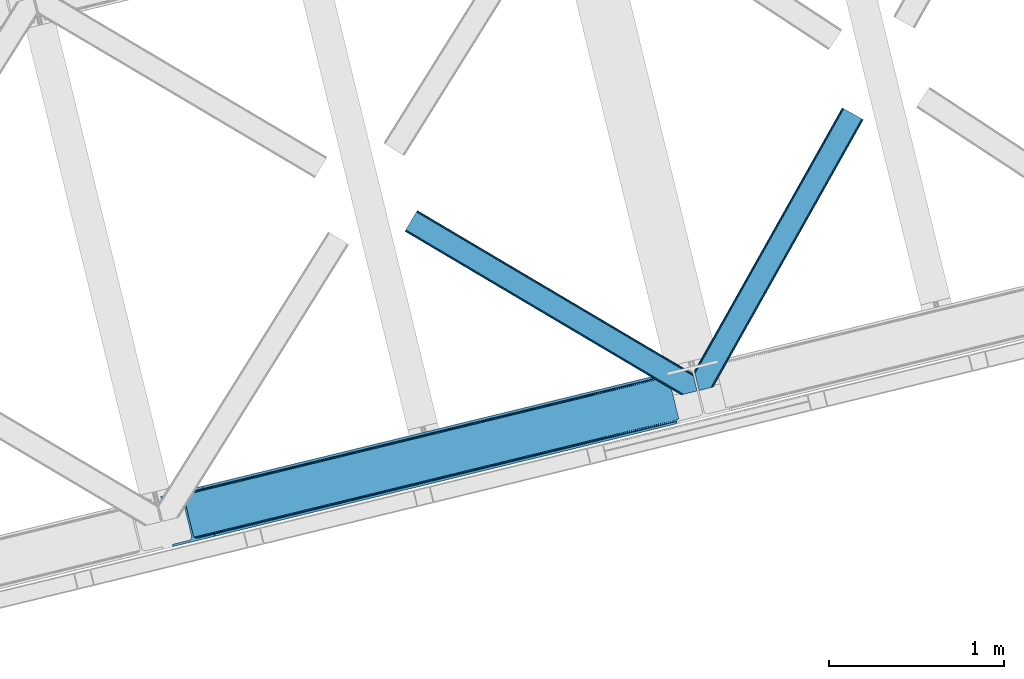
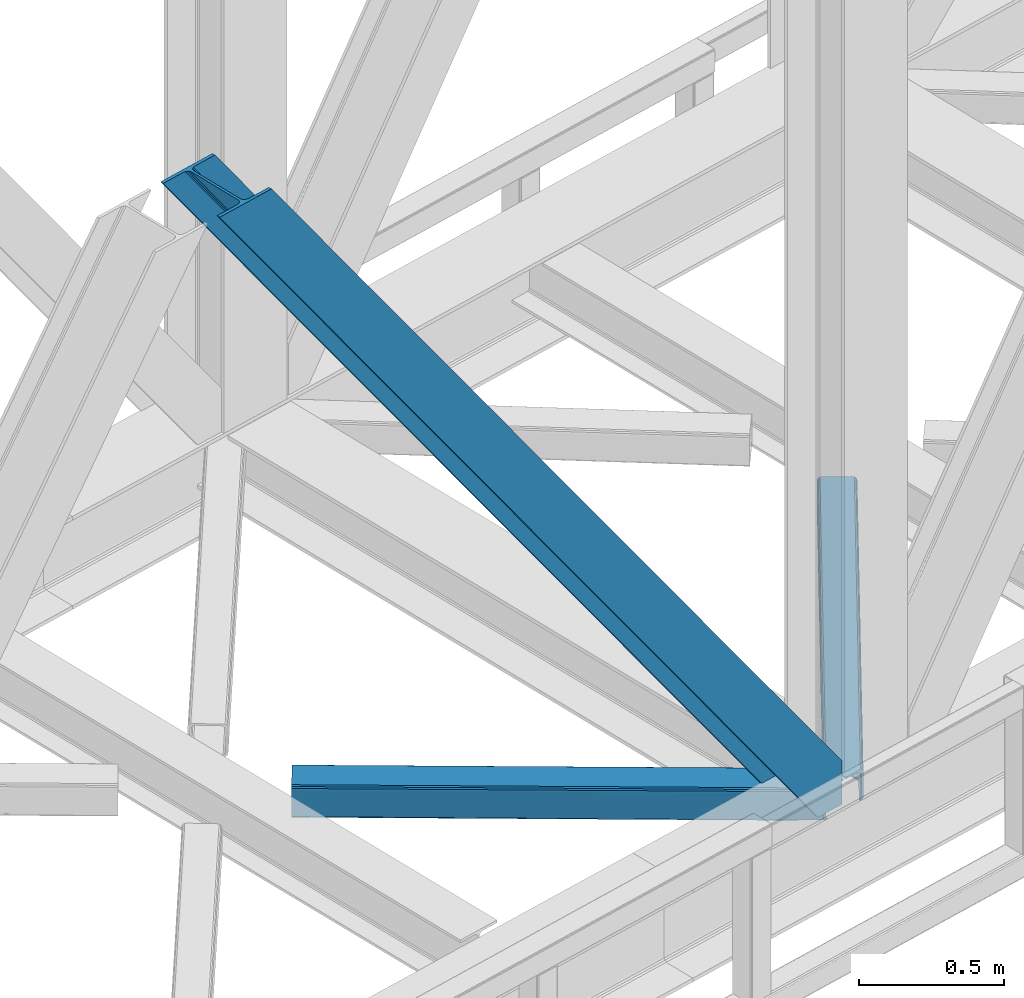
# One storey, part 70 of 92: 3 members.
"""IFC4 building model written with IfcOpenShell, lengths in millimetres."""

from ifc_helpers import new_model, entity, si_unit, converted_unit, derived_unit, direction, frame, origin, place, context, subcontext, project, spatial, triangles, type_object, element, save


model = new_model("IFC4")

# Units and contexts
model_context = context("Model", 3, precision=0.01, world=origin(), true_north=direction((6.12303176911189e-17, 1.0)))
plan_context = context("Plan", 3, precision=0.01, world=origin(), true_north=direction((6.12303176911189e-17, 1.0)))
body_context = subcontext(model_context, "Body", "Model", "MODEL_VIEW")
ifc_project = project(units=[si_unit("LENGTHUNIT", "METRE", prefix="MILLI"), si_unit("AREAUNIT", "SQUARE_METRE"), si_unit("VOLUMEUNIT", "CUBIC_METRE"), converted_unit("PLANEANGLEUNIT", "DEGREE", entity("IfcRatioMeasure", 0.0174532925199433), si_unit("PLANEANGLEUNIT", "RADIAN"), dimensions=[0, 0, 0, 0, 0, 0, 0]), si_unit("MASSUNIT", "GRAM", prefix="KILO"), derived_unit("MASSDENSITYUNIT", [(si_unit("MASSUNIT", "GRAM", prefix="KILO"), 1), (si_unit("LENGTHUNIT", "METRE"), -3)]), derived_unit("MOMENTOFINERTIAUNIT", [(si_unit("LENGTHUNIT", "METRE"), 4)]), si_unit("TIMEUNIT", "SECOND"), si_unit("FREQUENCYUNIT", "HERTZ"), si_unit("THERMODYNAMICTEMPERATUREUNIT", "DEGREE_CELSIUS"), derived_unit("THERMALTRANSMITTANCEUNIT", [(si_unit("MASSUNIT", "GRAM", prefix="KILO"), 1), (si_unit("THERMODYNAMICTEMPERATUREUNIT", "KELVIN"), -1), (si_unit("TIMEUNIT", "SECOND"), -3)]), derived_unit("VOLUMETRICFLOWRATEUNIT", [(si_unit("LENGTHUNIT", "METRE"), 3), (si_unit("TIMEUNIT", "SECOND"), -1)]), derived_unit("MASSFLOWRATEUNIT", [(si_unit("MASSUNIT", "GRAM", prefix="KILO"), 1), (si_unit("TIMEUNIT", "SECOND"), -1)]), derived_unit("ROTATIONALFREQUENCYUNIT", [(si_unit("TIMEUNIT", "SECOND"), -1)]), si_unit("ELECTRICCURRENTUNIT", "AMPERE"), si_unit("ELECTRICVOLTAGEUNIT", "VOLT"), si_unit("POWERUNIT", "WATT"), si_unit("FORCEUNIT", "NEWTON", prefix="KILO"), si_unit("ILLUMINANCEUNIT", "LUX"), si_unit("LUMINOUSFLUXUNIT", "LUMEN"), si_unit("LUMINOUSINTENSITYUNIT", "CANDELA"), derived_unit("USERDEFINED", [(si_unit("MASSUNIT", "GRAM", prefix="KILO"), -1), (si_unit("LENGTHUNIT", "METRE"), -2), (si_unit("TIMEUNIT", "SECOND"), 3), (si_unit("LUMINOUSFLUXUNIT", "LUMEN"), 1)]), derived_unit("LINEARVELOCITYUNIT", [(si_unit("LENGTHUNIT", "METRE"), 1), (si_unit("TIMEUNIT", "SECOND"), -1)]), si_unit("PRESSUREUNIT", "PASCAL"), derived_unit("USERDEFINED", [(si_unit("LENGTHUNIT", "METRE"), -2), (si_unit("MASSUNIT", "GRAM", prefix="KILO"), 1), (si_unit("TIMEUNIT", "SECOND"), -2)]), derived_unit("LINEARFORCEUNIT", [(si_unit("MASSUNIT", "GRAM", prefix="KILO"), 1), (si_unit("LENGTHUNIT", "METRE"), 1), (si_unit("TIMEUNIT", "SECOND"), -2), (si_unit("LENGTHUNIT", "METRE"), -1)]), derived_unit("PLANARFORCEUNIT", [(si_unit("MASSUNIT", "GRAM", prefix="KILO"), 1), (si_unit("LENGTHUNIT", "METRE"), 1), (si_unit("TIMEUNIT", "SECOND"), -2), (si_unit("LENGTHUNIT", "METRE"), -2)])], contexts=[model_context, plan_context])

# Site, building, storey
site_placement = place(None, origin())
site = spatial("IfcSite", under=ifc_project, at=site_placement, CompositionType="ELEMENT")
building_placement = place(site_placement, origin())
building = spatial("IfcBuilding", under=site, at=building_placement, CompositionType="ELEMENT")
storey_placement = place(building_placement, frame((0.0, 0.0, 15900.0)))
storey = spatial("IfcBuildingStorey", under=building, at=storey_placement, Name="05", CompositionType="ELEMENT", Elevation=15900.0)

# Members
member_type_1 = type_object("IfcMemberType", PredefinedType="BRACE")
member_1_placement = place(storey_placement, frame((-14085.95, 14033.19, 3695.0)))
element("IfcMember", 1, at=member_1_placement, inside=storey, type_object=member_type_1, ObjectType="Steel Vertical Brace", PredefinedType="BRACE", context=body_context, shape_type="Tessellation", body=[
    triangles([(2966.89216003418, 730.998403930664, 0.80925292968459), (2967.55374755859, 730.015905761718, 1.10690917968532), (2966.08058166504, 729.656625366211, 0.0), (2964.18651123047, 737.429406738282, 0.0), (2962.43894348145, 728.768307495116, 8.31577148437282), (2962.43894348145, 728.768307495116, 0.0), (2505.8586730957, 612.605630493164, 658.855133056641), (2511.3606628418, 609.931375122071, 662.301434326171), (2954.04410705566, 717.839904785156, 38.6743835449197), (2954.16968078613, 719.764205932617, 32.1678039550752), (2501.41243286133, 617.533236694335, 656.552947998047), (2958.54266967773, 726.956790161132, 14.8293273925774), (2955.07776489258, 722.243124389648, 26.1867736816384), (2955.64168395996, 723.795355224609, 22.4381652832017), (655.166986083985, 156.054428100586, 3289.34108276367), (649.438265991212, 156.067218017577, 3285.27854003906), (213.882293701172, 48.4865753173817, 3911.00081176758), (205.271191406249, 47.7970825195298, 3911.00081176758), (643.936276245116, 158.742636108398, 3281.83223876953), (197.320513916016, 49.8760253906239, 3911.00081176758), (639.490036010742, 163.669079589843, 3279.53005371094), (191.242977905273, 54.4048187255848, 3911.00081176758), (636.783224487304, 170.100082397461, 3278.7231262207), (187.962945556641, 60.695132446288, 3911.00081176758), (2954.16154174805, 716.45859375, 50.6410949707024), (2517.08822021484, 609.91742248535, 666.36397705078), (2051.60849304199, 496.451092529296, 1322.10767211914), (2045.87977294922, 496.465045166015, 1318.04512939453), (1580.39888305664, 382.999877929688, 1973.78882446289), (1586.12760314941, 382.985925292967, 1977.85369262695), (1114.91799316406, 269.533547973631, 2629.53251953125), (1120.64671325684, 269.519595336913, 2633.59738769531), (2040.37778320312, 499.140463256836, 1314.598828125), (1574.89805603027, 385.674133300781, 1970.34484863281), (1109.41716613769, 272.208966064452, 2626.08854370117), (2035.93154296875, 504.066906738281, 1312.29896850586), (1570.45065307617, 390.601739501952, 1968.04266357422), (1104.97092590332, 277.135409545897, 2623.78635864258), (2498.70562133789, 623.963076782225, 655.74602050781), (2033.22473144531, 510.496746826171, 1311.48971557617), (1567.74384155273, 397.031579589842, 1967.23341064453), (1102.26411437988, 283.565249633788, 2622.97710571289), (2909.00499572754, 963.80047302246, 0.0), (2443.52526855469, 850.335305786133, 655.74602050781), (1978.04437866211, 736.868975830077, 1311.48971557617), (1512.56348876953, 623.402645874023, 1967.23341064453), (1047.08259887695, 509.937478637694, 2622.97710571289), (581.602871704101, 396.47114868164, 3278.7231262207), (132.78143005371, 287.066198730468, 3911.00081176758), (307.434722900391, 71.2909973144524, 3911.00081176758), (2954.16154174805, 716.45859375, 182.433050537107), (2954.3522277832, 715.476095581054, 0.0), (2954.16968078613, 719.764205932617, 0.0), (2954.3522277832, 715.476095581054, 182.495837402341), (2955.64168395996, 723.795355224609, 0.0), (2958.54266967773, 726.956790161132, 0.0), (2957.19507751465, 703.817504882813, 182.495837402341), (310.513604736328, 58.6603729248036, 3911.00081176758), (2957.19507751465, 703.817504882813, 0.0), (2846.09255676269, 676.734274291992, 0.0), (69.8643402099606, 0.0, 3911.00081176758), (2843.01367492676, 689.364898681641, 0.0), (66.7854583740227, 12.6294616699215, 3911.00081176758), (160.337887573241, 35.4338836669922, 3911.00081176758), (2936.56610412598, 712.169320678711, 0.0), (2953.96039123535, 734.936535644531, 0.0), (2953.94295043945, 727.841619873047, 0.0), (177.732174682616, 58.2010986328114, 3911.00081176758), (177.714733886718, 51.1073455810547, 3911.00081176758), (2950.63036193848, 721.02459411621, 0.0), (174.402145385742, 44.2891571044911, 3911.00081176758), (2944.52840881348, 715.520278930664, 0.0), (168.300192260742, 38.7848419189449, 3911.00081176758), (2898.78003845215, 961.307601928711, 0.0), (122.551821899415, 284.573327636717, 3911.00081176758), (2872.85952758789, 973.516159057617, 0.0), (2881.47062988281, 974.205651855469, 0.0), (105.243576049805, 297.47021484375, 3911.00081176758), (96.6313110351566, 296.781884765624, 3911.00081176758), (2889.42130737305, 972.1278717041, 0.0), (113.193090820312, 295.392434692381, 3911.00081176758), (2895.49884338379, 967.597915649414, 0.0), (119.271789550781, 290.86364135742, 3911.00081176758), (3.07888183593786, 273.977462768555, 3911.00081176758), (2779.30709838867, 950.711737060547, 0.0), (2776.22821655273, 963.342361450195, 0.0), (0.0, 286.606924438476, 3911.00081176758), (142.214575195312, 306.482455444335, 3911.00081176758), (150.176879882813, 309.833413696288, 3911.00081176758), (136.111459350586, 300.979302978514, 3911.00081176758), (132.800033569336, 294.161114501952, 3911.00081176758), (240.650427246093, 345.268460083007, 3911.00081176758), (243.729309082031, 332.637835693358, 3911.00081176758), (2887.33073730469, 990.424429321289, 182.495837402341), (2887.33073730469, 990.424429321289, 0.0), (2890.45496520996, 977.805432128906, 182.433050537107), (2890.17242431641, 978.765838623047, 182.495837402341), (1522.42102661133, 644.332763671875, 1977.85369262695), (591.460409545898, 417.401266479492, 3289.34108276367), (1056.94129943848, 530.867596435546, 2633.59738769531), (1987.90191650391, 757.799093627929, 1322.10767211914), (2453.38280639648, 871.264260864258, 666.36397705078), (2890.45496520996, 977.805432128906, 50.6410949707024), (2890.17242431641, 978.765838623047, 0.0), (2890.98749084473, 976.525277709961, 38.6743835449197), (2892.14904785156, 974.998626708984, 33.1630920410134), (2891.98277893066, 974.874215698243, 0.0), (2893.56989135742, 973.138275146484, 26.4425720214822), (2895.14653930664, 971.973229980469, 22.4381652832017), (2903.46928710938, 970.684936523438, 8.31577148437282), (2903.46928710938, 970.684936523438, 0.0), (2899.17652587891, 970.50122680664, 0.0), (2899.17652587891, 970.50122680664, 14.8293273925774), (2895.14653930664, 971.973229980469, 0.0), (2907.11092529297, 971.573254394531, 0.0), (2444.64961853027, 863.71007080078, 658.855133056641), (2442.96948852539, 857.289532470702, 656.552947998047), (2908.44921569824, 970.754699707031, 0.80925292968459), (2908.58409118652, 971.932534790039, 1.10690917968532), (581.047091674805, 403.426538085936, 3279.53005371094), (582.727221679688, 409.845913696288, 3281.83223876953), (586.380487060547, 414.752590942382, 3285.27854003906), (2448.30288391113, 868.615585327148, 662.301434326171), (1977.48859863281, 743.823202514648, 1312.29896850586), (1512.00770874024, 630.358035278319, 1968.04266357422), (1046.52681884766, 516.891705322265, 2623.78635864258), (1979.16872863769, 750.243740844726, 1314.598828125), (1513.68900146484, 636.777410888672, 1970.34484863281), (1048.20811157226, 523.312243652343, 2626.08854370117), (1982.82199401856, 755.15041809082, 1318.04512939453), (1517.34110412598, 641.684088134765, 1973.78882446289), (1051.86137695313, 528.218920898436, 2629.53251953125)], [[1, 2, 3], [3, 4, 1], [2, 5, 6], [6, 3, 2], [7, 8, 9], [9, 10, 7], [11, 12, 5], [5, 1, 11], [11, 7, 13], [13, 14, 11], [14, 12, 11], [15, 16, 17], [18, 17, 16], [16, 19, 18], [20, 18, 19], [19, 21, 20], [22, 20, 21], [21, 23, 22], [24, 22, 23], [5, 2, 1], [10, 13, 7], [25, 9, 8], [8, 26, 25], [26, 8, 27], [28, 27, 8], [27, 28, 29], [29, 30, 27], [30, 29, 31], [31, 32, 30], [32, 31, 16], [16, 15, 32], [8, 7, 33], [33, 28, 8], [28, 33, 34], [34, 29, 28], [29, 34, 31], [35, 31, 34], [31, 35, 16], [19, 16, 35], [7, 11, 33], [36, 33, 11], [33, 36, 34], [37, 34, 36], [34, 37, 35], [38, 35, 37], [35, 38, 21], [21, 19, 35], [1, 4, 11], [39, 11, 4], [11, 39, 36], [40, 36, 39], [36, 40, 37], [41, 37, 40], [37, 41, 38], [42, 38, 41], [38, 42, 21], [23, 21, 42], [4, 43, 44], [45, 39, 44], [41, 40, 45], [41, 45, 46], [44, 39, 4], [45, 40, 39], [42, 41, 46], [46, 47, 42], [47, 48, 23], [49, 24, 48], [47, 23, 42], [48, 24, 23], [50, 51, 30], [30, 32, 50], [32, 15, 50], [17, 50, 15], [27, 30, 51], [51, 25, 26], [26, 27, 51], [52, 9, 25], [52, 53, 10], [10, 9, 52], [25, 51, 54], [54, 52, 25], [14, 53, 55], [53, 14, 13], [10, 53, 13], [56, 12, 55], [14, 55, 12], [6, 5, 56], [12, 56, 5], [57, 54, 58], [54, 51, 50], [50, 58, 54], [57, 59, 52], [52, 54, 57], [58, 60, 57], [58, 61, 60], [60, 59, 57], [62, 60, 63], [61, 63, 60], [63, 64, 62], [65, 62, 64], [66, 67, 68], [69, 68, 67], [67, 70, 69], [71, 69, 70], [70, 72, 71], [73, 71, 72], [72, 65, 73], [64, 73, 65], [74, 66, 75], [68, 75, 66], [76, 77, 78], [78, 79, 76], [77, 80, 81], [81, 78, 77], [80, 82, 83], [83, 81, 80], [82, 74, 75], [75, 83, 82], [79, 84, 85], [85, 76, 79], [86, 85, 87], [84, 87, 85], [75, 68, 49], [71, 73, 18], [64, 61, 17], [63, 61, 64], [73, 64, 17], [68, 69, 22], [69, 71, 20], [81, 88, 78], [87, 79, 89], [79, 78, 89], [87, 84, 79], [81, 83, 90], [83, 75, 91], [49, 68, 24], [17, 18, 73], [22, 69, 20], [18, 20, 71], [22, 24, 68], [58, 17, 61], [58, 50, 17], [89, 78, 88], [90, 83, 91], [49, 91, 75], [90, 88, 81], [89, 92, 87], [92, 89, 93], [92, 86, 87], [86, 92, 94], [95, 86, 94], [96, 97, 93], [97, 94, 92], [92, 93, 97], [98, 96, 93], [93, 99, 100], [99, 93, 89], [100, 98, 93], [96, 98, 101], [101, 102, 96], [103, 96, 102], [97, 104, 94], [95, 94, 104], [104, 105, 106], [96, 103, 97], [104, 97, 103], [103, 105, 104], [107, 108, 109], [107, 106, 108], [110, 111, 112], [112, 113, 110], [113, 112, 114], [114, 109, 113], [109, 114, 107], [106, 107, 104], [53, 70, 55], [76, 86, 95], [85, 86, 76], [77, 76, 95], [104, 80, 77], [77, 95, 104], [104, 107, 80], [60, 65, 59], [52, 72, 70], [65, 72, 59], [60, 62, 65], [70, 53, 52], [52, 59, 72], [43, 66, 74], [82, 112, 74], [80, 114, 82], [80, 107, 114], [82, 114, 112], [111, 43, 74], [112, 111, 74], [43, 111, 115], [4, 66, 43], [56, 66, 6], [55, 70, 67], [67, 66, 56], [56, 55, 67], [4, 6, 66], [3, 6, 4], [116, 113, 109], [117, 118, 113], [113, 116, 117], [109, 108, 116], [118, 119, 110], [110, 113, 118], [48, 120, 91], [91, 49, 48], [120, 121, 90], [90, 91, 120], [121, 122, 88], [88, 90, 121], [122, 99, 89], [89, 88, 122], [105, 103, 123], [102, 123, 103], [106, 116, 108], [116, 106, 105], [123, 116, 105], [43, 118, 44], [117, 44, 118], [44, 117, 124], [124, 45, 44], [45, 124, 125], [125, 46, 45], [46, 125, 126], [126, 47, 46], [47, 126, 120], [120, 48, 47], [117, 116, 127], [127, 124, 117], [124, 127, 128], [128, 125, 124], [125, 128, 129], [129, 126, 125], [126, 129, 121], [121, 120, 126], [116, 123, 127], [130, 127, 123], [127, 130, 128], [131, 128, 130], [128, 131, 132], [132, 129, 128], [129, 132, 122], [122, 121, 129], [123, 102, 101], [101, 130, 123], [130, 101, 131], [98, 131, 101], [131, 98, 132], [100, 132, 98], [132, 100, 122], [99, 122, 100], [110, 119, 111], [115, 111, 119], [119, 118, 115], [43, 115, 118]]),
])
member_type_2 = type_object("IfcMemberType", PredefinedType="BRACE")
member_2_placement = place(storey_placement, frame((-11031.43, 14926.18, 3510.0)))
element("IfcMember", 2, at=member_2_placement, inside=storey, type_object=member_type_2, ObjectType="Steel Horizontal Brace", PredefinedType="BRACE", context=body_context, shape_type="Tessellation", body=[
    triangles([(967.681631469726, 1549.66471252442, 122.500662231447), (966.517749023436, 1550.31583557129, 129.197927856447), (108.48872680664, 19.7604217529297, 122.500662231447), (106.717904663084, 19.3290527343761, 129.197927856447), (963.210974121093, 1552.17386169434, 134.874325561526), (101.675189208983, 18.1000579833999, 134.874325561526), (958.258950805663, 1554.95276184082, 138.667117309571), (94.1337890625, 16.2617980957039, 138.667117309571), (952.418609619141, 1558.23279418945, 139.999594116212), (85.2320068359368, 14.0921630859375, 139.999594116212), (967.681631469726, 1549.66471252442, 17.5000946044929), (108.48872680664, 19.7604217529297, 17.5000946044929), (6.07521057128906, 87.5702362060547, 139.999594116212), (27.4215820312493, 0.0, 139.999594116212), (860.870709228515, 1609.64826049805, 139.999594116212), (855.030368041991, 1612.92713012695, 138.667117309571), (3.75093383788953, 97.1068634033218, 138.667117309571), (850.082995605468, 1615.70719299317, 134.874325561526), (1.7801239013661, 105.192416381837, 134.874325561526), (846.772732543945, 1617.56405639648, 129.197927856447), (0.46276245117042, 110.594412231447, 129.197927856447), (845.612338256835, 1618.21750488281, 122.500662231447), (0.0, 112.491970825196, 122.500662231447), (845.612338256835, 1618.21750488281, 17.5000946044929), (0.0, 112.491970825196, 17.5000946044929), (966.517749023436, 1550.31583557129, 10.8028289794929), (963.210974121093, 1552.17386169434, 5.12526855468968), (157.746185302734, 111.400177001953, 9.52034912109593), (158.140347290038, 112.965197753907, 8.76225585937573), (158.27173461914, 113.467492675782, 8.52041015625218), (157.353186035156, 117.235867309571, 5.12526855468968), (106.36094970703, 19.2418487548839, 10.8679412841811), (105.931906127929, 19.1372039794933, 9.52034912109593), (952.418609619141, 1558.23279418945, 0.0), (958.258950805663, 1554.95276184082, 1.33247680664135), (153.058099365233, 134.858047485352, 0.0), (155.382376098632, 125.321420288086, 1.33247680664135), (124.438916015624, 252.261346435547, 0.0), (94.4581878662102, 244.952490234376, 0.0), (860.870709228515, 1609.64826049805, 0.0), (153.051123046875, 130.664117431641, 9.52034912109593), (153.142977905272, 131.5815032959, 9.31571044922021), (153.232507324217, 132.509353637695, 9.10758361816625), (153.325524902342, 133.426739501954, 8.90294494629052), (152.944152832031, 135.321972656251, 8.42274169922166), (87.952770996093, 14.7549133300781, 9.52034912109593), (150.628015136717, 144.8272064209, 6.99957275390625), (124.438916015624, 252.261346435547, 6.99957275390625), (952.15816040039, 1558.38162231445, 8.3320495605476), (946.317819213866, 1561.66049194336, 6.99957275390625), (957.105532836913, 1555.60039672852, 12.1260040283232), (92.375756835936, 15.832754516603, 12.1260040283232), (961.576190185546, 1553.09124755859, 24.4996673583992), (960.415795898436, 1553.7435333252, 17.8035644531265), (99.1858062744141, 17.4931182861328, 24.4996673583992), (97.4138214111317, 17.0617492675792, 17.8035644531265), (103.762271118163, 247.220956420899, 6.99957275390625), (866.972662353515, 1606.21940002442, 6.99957275390625), (85.5610565185543, 242.784017944337, 1.33247680664135), (91.7385864257813, 244.289739990236, 9.52034912109593), (78.0161682128892, 240.944595336914, 5.12526855468968), (95.0593139648427, 245.098992919922, 8.82504272460938), (73.7641021728505, 239.908612060548, 9.52034912109593), (846.772732543945, 1617.56405639648, 10.8028289794929), (4.59390563964735, 117.490502929688, 10.8702667236357), (850.082995605468, 1615.70719299317, 5.12526855468968), (5.69267578124891, 118.696243286133, 9.52034912109593), (855.030368041991, 1612.92713012695, 1.33247680664135), (0.0104644775383349, 112.452438354492, 16.5199218750022), (10.3889007568359, 99.4323028564468, 9.52034912109593), (7.36001586914063, 100.839193725587, 12.1260040283232), (3.09864807128906, 99.7811187744155, 16.5199218750022), (852.878173828125, 1614.13752136231, 17.8035644531265), (851.714291381835, 1614.78864440918, 24.4996673583992), (2.43008422851563, 102.522811889648, 24.4996673583992), (2.98586425781104, 100.243881225586, 17.8686767578147), (856.183786010741, 1612.27949523926, 12.1260040283232), (861.136972045897, 1609.49943237305, 8.3320495605476), (961.576190185546, 1553.09124755859, 115.501089477541), (99.1858062744141, 17.4931182861328, 115.501089477541), (97.4138214111317, 17.0617492675792, 122.196029663086), (84.8297058105454, 13.9933319091797, 131.667544555665), (75.9325744628895, 11.8248596191406, 133.000021362306), (27.4215820312493, 0.0, 133.000021362306), (92.375756835936, 15.832754516603, 127.87475280762), (946.317819213866, 1561.66049194336, 133.000021362306), (952.15816040039, 1558.38162231445, 131.667544555665), (957.105532836913, 1555.60039672852, 127.87475280762), (960.415795898436, 1553.7435333252, 122.196029663086), (856.183786010741, 1612.27949523926, 127.87475280762), (866.972662353515, 1606.21940002442, 133.000021362306), (861.136972045897, 1609.49943237305, 131.667544555665), (851.714291381835, 1614.78864440918, 115.501089477541), (852.878173828125, 1614.13752136231, 122.196029663086), (6.18101806640516, 87.1388671875011, 131.667544555665), (8.50529479980469, 77.6010772705085, 133.000021362306), (4.21020812988172, 95.2232574462905, 127.87475280762), (2.43008422851563, 102.522811889648, 115.501089477541), (2.89284667968604, 100.626416015626, 122.196029663086)], [[1, 2, 3], [4, 3, 2], [2, 5, 4], [6, 4, 5], [5, 7, 6], [8, 6, 7], [7, 9, 8], [10, 8, 9], [11, 1, 3], [3, 12, 11], [13, 10, 9], [10, 13, 14], [9, 15, 13], [15, 16, 17], [17, 13, 15], [16, 18, 19], [19, 17, 16], [18, 20, 21], [21, 19, 18], [20, 22, 23], [23, 21, 20], [22, 24, 25], [25, 23, 22], [26, 11, 12], [27, 28, 29], [30, 31, 27], [26, 32, 28], [28, 27, 26], [32, 33, 28], [34, 35, 36], [37, 36, 35], [35, 27, 37], [31, 37, 27], [12, 32, 26], [38, 39, 40], [36, 38, 34], [40, 34, 38], [41, 42, 28], [42, 43, 29], [43, 44, 29], [44, 45, 30], [33, 46, 28], [41, 28, 46], [45, 47, 36], [38, 47, 48], [47, 38, 36], [45, 31, 30], [45, 36, 37], [37, 31, 45], [49, 50, 47], [51, 49, 45], [45, 44, 51], [51, 43, 42], [43, 51, 44], [42, 41, 51], [51, 41, 52], [46, 52, 41], [47, 45, 49], [53, 54, 55], [56, 55, 54], [54, 51, 56], [52, 56, 51], [48, 47, 50], [57, 48, 58], [50, 58, 48], [59, 60, 61], [57, 38, 48], [57, 62, 39], [57, 39, 38], [39, 60, 59], [61, 60, 63], [62, 60, 39], [24, 64, 65], [65, 25, 24], [65, 64, 63], [64, 66, 61], [61, 63, 64], [63, 67, 65], [66, 68, 59], [59, 61, 66], [68, 40, 39], [39, 59, 68], [65, 69, 25], [65, 70, 71], [65, 67, 70], [71, 69, 65], [72, 69, 71], [70, 67, 60], [63, 60, 67], [73, 74, 75], [73, 72, 71], [73, 76, 72], [77, 71, 60], [60, 78, 77], [60, 62, 78], [71, 70, 60], [78, 62, 57], [57, 58, 78], [71, 77, 73], [75, 76, 73], [79, 53, 55], [55, 80, 79], [81, 3, 4], [82, 8, 10], [14, 83, 10], [83, 14, 84], [83, 82, 10], [85, 8, 82], [85, 81, 6], [6, 8, 85], [4, 6, 81], [55, 12, 3], [52, 33, 56], [81, 80, 3], [52, 46, 33], [55, 56, 12], [80, 55, 3], [32, 12, 56], [56, 33, 32], [86, 87, 82], [82, 83, 86], [87, 88, 85], [85, 82, 87], [88, 89, 81], [81, 85, 88], [89, 79, 80], [80, 81, 89], [26, 51, 54], [53, 1, 11], [26, 54, 11], [26, 27, 51], [54, 53, 11], [51, 27, 35], [50, 34, 40], [34, 49, 35], [49, 34, 50], [49, 51, 35], [2, 88, 5], [79, 1, 53], [1, 89, 2], [89, 1, 79], [2, 89, 88], [9, 86, 15], [7, 5, 88], [88, 87, 7], [87, 86, 9], [9, 7, 87], [77, 68, 66], [40, 58, 50], [40, 78, 58], [78, 40, 68], [77, 78, 68], [74, 24, 22], [64, 73, 77], [66, 64, 77], [73, 64, 24], [74, 73, 24], [16, 90, 18], [15, 86, 91], [91, 92, 15], [92, 90, 16], [16, 15, 92], [20, 18, 90], [22, 93, 74], [94, 22, 20], [22, 94, 93], [94, 20, 90], [95, 96, 13], [96, 14, 13], [96, 84, 14], [17, 95, 13], [97, 17, 19], [97, 95, 17], [72, 76, 69], [23, 98, 99], [99, 19, 21], [19, 99, 97], [21, 23, 99], [23, 75, 98], [25, 69, 76], [25, 75, 23], [75, 25, 76], [83, 96, 86], [83, 84, 96], [91, 86, 96], [74, 93, 75], [98, 75, 93], [93, 94, 98], [99, 98, 94], [94, 90, 99], [97, 99, 90], [90, 92, 97], [95, 97, 92], [92, 91, 95], [96, 95, 91]]),
])
member_type_3 = type_object("IfcMemberType", PredefinedType="BRACE")
member_3_placement = place(storey_placement, frame((-12687.88, 14901.03, 3510.0)))
element("IfcMember", 3, at=member_3_placement, inside=storey, type_object=member_type_3, ObjectType="Steel Horizontal Brace", PredefinedType="BRACE", context=body_context, shape_type="Tessellation", body=[
    triangles([(1468.19991760254, 208.966314697265, 0.0), (1502.96058654785, 66.3657165527329, 0.0), (8.91340942382703, 950.879168701171, 0.0), (62.4054931640621, 1041.23295593262, 0.0), (0.677865600584482, 936.96722717285, 10.8028289794929), (1582.93710021973, 0.542990112304324, 10.8679412841811), (1580.70932922363, 0.0, 17.5000946044929), (1509.31950073242, 44.5019348144524, 9.52034912109593), (2.61030578613281, 940.230981445311, 5.12526855468968), (1507.05684814453, 49.5597656249993, 5.12526855468968), (1507.93353881836, 45.9669616699211, 8.52041015625218), (1508.98463745117, 44.8554016113267, 9.27850341796875), (1508.62884521484, 45.2344482421868, 9.02037963867406), (1508.26840209961, 45.6123321533196, 8.76225585937573), (1583.38939819336, 0.653448486327761, 9.52034912109593), (1505.17789306641, 57.2709228515614, 1.33247680664135), (5.50315246581886, 945.116729736328, 1.33247680664135), (0.0, 935.820785522461, 17.5000946044929), (1580.70932922363, 0.0, 122.500662231447), (0.0, 935.820785522461, 122.500662231447), (1595.73399353027, 3.66256713867188, 138.667117309571), (1605.04156494141, 5.93103332519422, 139.999594116212), (8.91340942382703, 950.879168701171, 139.999594116212), (5.50315246581886, 945.116729736328, 138.667117309571), (1587.83912658691, 1.73826599121094, 134.874325561526), (2.61030578613281, 940.230981445311, 134.874325561526), (1582.56154174805, 0.451135253904795, 129.197927856447), (0.677865600584482, 936.96722717285, 129.197927856447), (1503.00476989746, 66.183169555663, 8.52041015625218), (1503.36521301269, 65.041378784179, 8.90294494629052), (1503.8558807373, 64.3216552734375, 9.10758361816625), (1504.35003662109, 63.5914672851559, 9.31571044922021), (1504.84186706543, 62.8729064941399, 9.52034912109593), (1602.19522705078, 5.23688964843677, 9.52034912109593), (9.06572570800745, 951.139617919922, 8.3320495605476), (1502.85361633301, 66.8075500488267, 8.42274169922166), (6.17287902831958, 946.253869628905, 12.1260040283232), (1597.57225341797, 4.11021423339844, 12.1260040283232), (1500.64328613281, 75.8721130371086, 6.99957275390625), (12.4817962646484, 956.903219604492, 6.99957275390625), (1592.2946685791, 2.82424621581958, 17.8035644531265), (4.2450897216786, 942.991278076172, 17.8035644531265), (1590.44245605469, 2.3719482421875, 24.4996673583992), (3.56257324218677, 941.843673706055, 24.4996673583992), (1470.5183807373, 199.458755493164, 6.99957275390625), (58.8371063232407, 1035.2089050293, 6.99957275390625), (1463.22812805176, 229.365069580077, 8.52041015625218), (1468.15573425293, 209.147698974608, 8.52041015625218), (1464.10365600586, 225.771102905273, 5.12526855468968), (1468.30805053711, 208.524481201172, 8.42274169922166), (1465.98377380371, 218.061108398437, 1.33247680664135), (1590.44245605469, 2.3719482421875, 115.501089477541), (3.56257324218677, 941.843673706055, 115.501089477541), (1592.2946685791, 2.82424621581958, 122.196029663086), (4.2450897216786, 942.991278076172, 122.196029663086), (1597.57225341797, 4.11021423339844, 127.87475280762), (6.17287902831958, 946.253869628905, 127.87475280762), (1605.46712036133, 6.03451538085938, 131.667544555665), (9.06572570800745, 951.139617919922, 131.667544555665), (1614.77469177246, 8.30414428710901, 133.000021362306), (12.4817962646484, 956.903219604492, 133.000021362306), (1672.21072082519, 22.304452514647, 139.999594116212), (1672.21072082519, 22.304452514647, 133.000021362306), (1653.44209899902, 99.2985900878903, 139.999594116212), (62.4054931640621, 1041.23295593262, 139.999594116212), (1655.75939941406, 89.7910308837891, 133.000021362306), (58.8371063232407, 1035.2089050293, 133.000021362306), (1648.09010009766, 121.255389404296, 129.197927856447), (1647.64942932129, 123.064581298828, 122.500662231447), (70.6421997070302, 1055.14489746094, 129.197927856447), (71.3200653076165, 1056.29133911133, 122.500662231447), (1649.34583740234, 116.103378295898, 134.874325561526), (68.7085968017564, 1051.88114318848, 134.874325561526), (1651.22479248047, 108.393383789062, 138.667117309571), (65.8157501220703, 1046.99539489746, 138.667117309571), (1647.64942932129, 123.064581298828, 17.5000946044929), (71.3200653076165, 1056.29133911133, 17.5000946044929), (70.6421997070302, 1055.14489746094, 10.8028289794929), (65.1413726806641, 1045.85709228516, 12.1260040283232), (67.0738128662106, 1049.12084655762, 17.8035644531265), (67.7516784667969, 1050.26728820801, 24.4996673583992), (68.7085968017564, 1051.88114318848, 5.12526855468968), (65.8157501220703, 1046.99539489746, 1.33247680664135), (62.2485260009762, 1040.97134399414, 8.3320495605476), (65.1413726806641, 1045.85709228516, 127.87475280762), (67.7516784667969, 1050.26728820801, 115.501089477541), (67.0738128662106, 1049.12084655762, 122.196029663086), (62.2485260009762, 1040.97134399414, 131.667544555665), (1649.96672973633, 113.558184814452, 24.4996673583992), (1649.96672973633, 113.558184814452, 115.501089477541), (1653.54209289551, 98.886987304686, 131.667544555665), (1651.66313781738, 106.596981811523, 127.87475280762), (1650.40740051269, 111.748992919922, 122.196029663086), (1650.49576721191, 111.385061645507, 17.8686767578147), (1650.60390014648, 110.943228149414, 16.5199218750022), (1647.65756835937, 123.027374267578, 16.5199218750022), (1641.3730682373, 124.97144165039, 10.8702667236357), (1463.44788208008, 229.701095581055, 9.22734375000073), (1463.33974914551, 229.533663940429, 8.87387695312646), (1464.24667053223, 229.405764770507, 9.52034912109593), (1639.86618347168, 125.435366821288, 9.52034912109593), (1646.38090209961, 109.727023315429, 12.1260040283232), (1468.72546691894, 211.034793090819, 9.52034912109593), (1644.3449798584, 107.063232421875, 9.52034912109593)], [[1, 2, 3], [3, 4, 1], [5, 6, 7], [6, 5, 8], [5, 9, 10], [10, 11, 5], [12, 5, 13], [12, 8, 5], [5, 14, 13], [5, 11, 14], [8, 15, 6], [16, 10, 9], [9, 17, 16], [2, 16, 17], [17, 3, 2], [7, 18, 5], [7, 19, 18], [20, 18, 19], [21, 22, 23], [23, 24, 21], [25, 21, 24], [24, 26, 25], [27, 25, 26], [26, 28, 27], [19, 27, 28], [28, 20, 19], [11, 29, 30], [14, 30, 31], [13, 31, 32], [12, 32, 33], [33, 8, 12], [32, 12, 13], [31, 13, 14], [30, 14, 11], [34, 15, 33], [8, 33, 15], [35, 30, 29], [32, 35, 33], [35, 32, 31], [30, 35, 31], [29, 36, 35], [37, 38, 33], [33, 35, 37], [38, 34, 33], [35, 36, 39], [39, 40, 35], [41, 38, 37], [37, 42, 41], [43, 41, 42], [42, 44, 43], [39, 45, 40], [46, 40, 45], [1, 45, 39], [47, 48, 49], [48, 50, 1], [45, 1, 50], [48, 51, 49], [48, 1, 51], [2, 1, 39], [2, 39, 36], [29, 2, 36], [11, 10, 29], [29, 16, 2], [29, 10, 16], [52, 43, 44], [44, 53, 52], [54, 52, 55], [53, 55, 52], [56, 54, 57], [55, 57, 54], [58, 56, 59], [57, 59, 56], [60, 58, 61], [59, 61, 58], [56, 58, 21], [25, 56, 21], [25, 27, 54], [56, 25, 54], [54, 27, 19], [58, 22, 21], [62, 60, 63], [62, 22, 60], [58, 60, 22], [54, 19, 52], [43, 7, 41], [19, 43, 52], [7, 6, 41], [19, 7, 43], [15, 41, 6], [38, 41, 15], [34, 38, 15], [22, 64, 23], [22, 62, 64], [65, 23, 64], [66, 60, 61], [60, 66, 63], [61, 67, 66], [68, 69, 70], [71, 70, 69], [72, 68, 73], [70, 73, 68], [74, 72, 75], [73, 75, 72], [64, 74, 65], [75, 65, 74], [69, 76, 77], [77, 71, 69], [78, 79, 80], [81, 71, 77], [78, 80, 77], [78, 82, 79], [80, 81, 77], [79, 82, 83], [46, 4, 3], [4, 84, 83], [84, 4, 46], [84, 79, 83], [70, 85, 73], [86, 71, 81], [71, 87, 70], [87, 71, 86], [70, 87, 85], [65, 67, 23], [75, 73, 85], [85, 88, 75], [88, 67, 65], [65, 75, 88], [37, 17, 9], [3, 40, 46], [3, 35, 40], [35, 3, 17], [37, 35, 17], [44, 18, 20], [5, 42, 37], [9, 5, 37], [42, 5, 18], [44, 42, 18], [24, 57, 26], [23, 67, 61], [61, 59, 23], [59, 57, 24], [24, 23, 59], [28, 26, 57], [20, 53, 44], [55, 20, 28], [20, 55, 53], [55, 28, 57], [89, 90, 86], [86, 81, 89], [91, 66, 67], [67, 88, 91], [92, 91, 88], [88, 85, 92], [93, 92, 85], [85, 87, 93], [90, 93, 87], [87, 86, 90], [92, 72, 74], [66, 91, 64], [91, 92, 74], [94, 95, 96], [63, 66, 62], [64, 62, 66], [91, 74, 64], [94, 76, 89], [69, 90, 89], [89, 76, 69], [94, 96, 76], [69, 93, 90], [93, 72, 92], [72, 93, 68], [69, 68, 93], [77, 76, 97], [76, 96, 97], [98, 99, 82], [47, 82, 99], [47, 49, 82], [78, 97, 100], [100, 82, 78], [100, 98, 82], [97, 101, 100], [51, 1, 4], [4, 83, 51], [49, 51, 83], [83, 82, 49], [97, 78, 77], [80, 79, 102], [102, 95, 80], [80, 94, 89], [46, 45, 50], [103, 102, 79], [103, 104, 102], [50, 79, 84], [50, 103, 79], [50, 84, 46], [89, 81, 80], [95, 94, 80], [96, 102, 97], [102, 96, 95], [102, 101, 97], [102, 104, 101], [101, 104, 103], [103, 100, 101]]),
])

save(model, "model.ifc")
